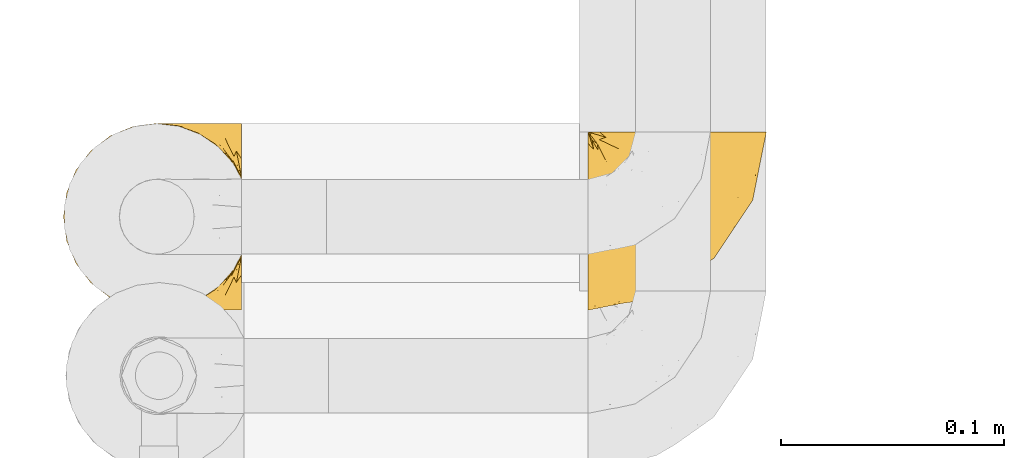
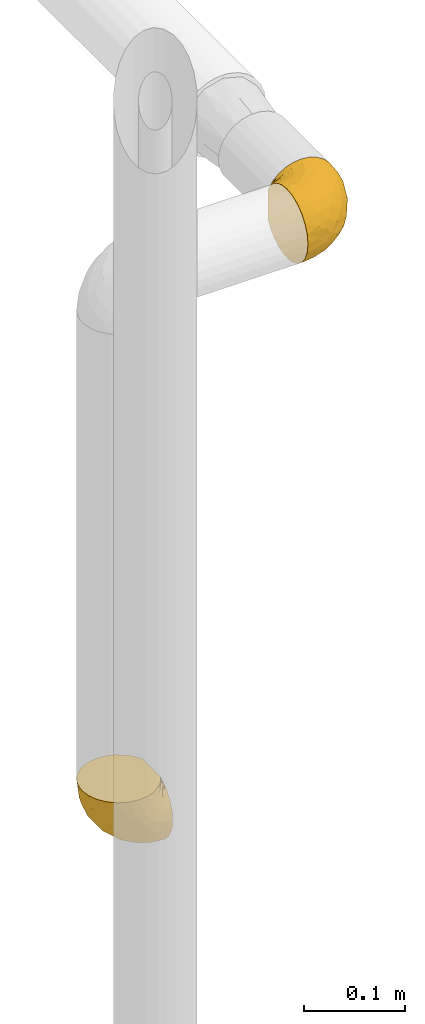
# One storey, part 125 of 827: 2 coverings.
"""IFC2X3 building model written with IfcOpenShell, lengths in millimetres."""

from ifc_helpers import new_model, entity, si_unit, converted_unit, derived_unit, direction, frame, origin, place, context, subcontext, project, spatial, faceted_brep, element, save


model = new_model("IFC2X3")

# Units and contexts
model_context = context("Model", 3, precision=0.01, world=origin(), true_north=direction((6.12303176911189e-17, 1.0)))
body_context = subcontext(model_context, "Body", "Model", "MODEL_VIEW")
ifc_project = project(units=[si_unit("LENGTHUNIT", "METRE", prefix="MILLI"), si_unit("AREAUNIT", "SQUARE_METRE"), si_unit("VOLUMEUNIT", "CUBIC_METRE"), converted_unit("PLANEANGLEUNIT", "DEGREE", entity("IfcRatioMeasure", 0.0174532925199433), si_unit("PLANEANGLEUNIT", "RADIAN"), dimensions=[0, 0, 0, 0, 0, 0, 0]), si_unit("MASSUNIT", "GRAM", prefix="KILO"), derived_unit("MASSDENSITYUNIT", [(si_unit("MASSUNIT", "GRAM", prefix="KILO"), 1), (si_unit("LENGTHUNIT", "METRE"), -3)]), derived_unit("MOMENTOFINERTIAUNIT", [(si_unit("LENGTHUNIT", "METRE"), 4)]), si_unit("TIMEUNIT", "SECOND"), si_unit("FREQUENCYUNIT", "HERTZ"), si_unit("THERMODYNAMICTEMPERATUREUNIT", "DEGREE_CELSIUS"), derived_unit("THERMALTRANSMITTANCEUNIT", [(si_unit("MASSUNIT", "GRAM", prefix="KILO"), 1), (si_unit("THERMODYNAMICTEMPERATUREUNIT", "KELVIN"), -1), (si_unit("TIMEUNIT", "SECOND"), -3)]), derived_unit("VOLUMETRICFLOWRATEUNIT", [(si_unit("LENGTHUNIT", "METRE"), 3), (si_unit("TIMEUNIT", "SECOND"), -1)]), derived_unit("MASSFLOWRATEUNIT", [(si_unit("MASSUNIT", "GRAM", prefix="KILO"), 1), (si_unit("TIMEUNIT", "SECOND"), -1)]), derived_unit("ROTATIONALFREQUENCYUNIT", [(si_unit("TIMEUNIT", "SECOND"), -1)]), si_unit("ELECTRICCURRENTUNIT", "AMPERE"), si_unit("ELECTRICVOLTAGEUNIT", "VOLT"), si_unit("POWERUNIT", "WATT"), si_unit("FORCEUNIT", "NEWTON", prefix="KILO"), si_unit("ILLUMINANCEUNIT", "LUX"), si_unit("LUMINOUSFLUXUNIT", "LUMEN"), si_unit("LUMINOUSINTENSITYUNIT", "CANDELA"), derived_unit("USERDEFINED", [(si_unit("MASSUNIT", "GRAM", prefix="KILO"), -1), (si_unit("LENGTHUNIT", "METRE"), -2), (si_unit("TIMEUNIT", "SECOND"), 3), (si_unit("LUMINOUSFLUXUNIT", "LUMEN"), 1)]), derived_unit("LINEARVELOCITYUNIT", [(si_unit("LENGTHUNIT", "METRE"), 1), (si_unit("TIMEUNIT", "SECOND"), -1)]), si_unit("PRESSUREUNIT", "PASCAL"), derived_unit("USERDEFINED", [(si_unit("LENGTHUNIT", "METRE"), -2), (si_unit("MASSUNIT", "GRAM", prefix="KILO"), 1), (si_unit("TIMEUNIT", "SECOND"), -2)]), derived_unit("LINEARFORCEUNIT", [(si_unit("MASSUNIT", "GRAM", prefix="KILO"), 1), (si_unit("LENGTHUNIT", "METRE"), 1), (si_unit("TIMEUNIT", "SECOND"), -2), (si_unit("LENGTHUNIT", "METRE"), -1)]), derived_unit("PLANARFORCEUNIT", [(si_unit("MASSUNIT", "GRAM", prefix="KILO"), 1), (si_unit("LENGTHUNIT", "METRE"), 1), (si_unit("TIMEUNIT", "SECOND"), -2), (si_unit("LENGTHUNIT", "METRE"), -2)])], contexts=[model_context])

# Site, building, storey
site_placement = place(None, origin())
site = spatial("IfcSite", under=ifc_project, at=site_placement, CompositionType="ELEMENT")
building_placement = place(site_placement, origin())
building = spatial("IfcBuilding", under=site, at=building_placement, CompositionType="ELEMENT")
storey_placement = place(building_placement, frame((0.0, 0.0, 28200.0)))
storey = spatial("IfcBuildingStorey", under=building, at=storey_placement, Name="08", CompositionType="ELEMENT", Elevation=28200.0)

# Coverings
covering_1_placement = place(storey_placement, frame((11965.87, 16522.41, 1650.82)))
element("IfcCovering", 1, at=covering_1_placement, inside=storey, Name=":ADSK_", ObjectType=":ADSK_", PredefinedType="INSULATION", context=body_context, shape_type="Brep", body=[
    faceted_brep([(57.76, 81.45, 81.15), (65.69, 81.45, 76.16), (72.32, 81.45, 69.53), (77.3, 81.45, 61.6), (80.4, 81.45, 52.75), (81.45, 81.45, 43.45), (80.39, 81.45, 34.13), (77.3, 81.45, 25.28), (72.31, 81.45, 17.35), (65.68, 81.45, 10.72), (57.75, 81.45, 5.74), (48.9, 81.45, 2.64), (39.6, 81.45, 1.6), (30.22, 81.45, 2.66), (21.33, 81.45, 5.79), (13.37, 81.45, 10.83), (6.73, 81.45, 17.53), (1.77, 81.45, 25.53), (1.77, 81.45, 26.45), (1.77, 81.45, 27.37), (1.77, 81.45, 28.17), (1.77, 81.45, 29.49), (1.77, 81.45, 30.81), (1.77, 81.45, 32.13), (1.77, 81.45, 33.45), (1.77, 81.45, 34.78), (1.77, 81.45, 36.1), (1.77, 81.45, 37.42), (1.77, 81.45, 38.74), (1.77, 81.45, 40.06), (1.77, 81.45, 41.38), (1.77, 81.45, 42.7), (1.77, 81.45, 44.02), (1.77, 81.45, 45.34), (1.77, 81.45, 46.66), (1.77, 81.45, 47.58), (1.77, 81.45, 48.5), (1.77, 81.45, 49.41), (1.77, 81.45, 50.33), (1.77, 81.45, 51.25), (1.77, 81.45, 52.17), (1.77, 81.45, 53.09), (1.77, 81.45, 54.01), (1.77, 81.45, 54.93), (1.77, 81.45, 55.85), (1.77, 81.45, 56.76), (1.77, 81.45, 57.68), (1.77, 81.45, 58.6), (1.77, 81.45, 59.52), (1.77, 81.45, 60.44), (1.77, 81.45, 61.36), (6.74, 81.45, 69.37), (13.38, 81.45, 76.07), (21.35, 81.45, 81.11), (30.24, 81.45, 84.24), (39.6, 81.45, 85.3), (48.91, 81.45, 84.24), (1.6, 76.3, 17.52), (1.6, 69.67, 10.83), (1.6, 61.7, 5.79), (1.6, 52.81, 2.66), (1.6, 43.45, 1.6), (1.6, 32.61, 3.02), (1.6, 22.52, 7.2), (1.6, 13.85, 13.85), (1.6, 7.2, 22.52), (1.6, 3.02, 32.61), (1.6, 1.6, 43.45), (1.6, 3.02, 54.28), (1.6, 7.2, 64.37), (1.6, 13.85, 73.04), (1.6, 22.52, 79.69), (1.6, 32.61, 83.87), (1.6, 43.45, 85.3), (1.6, 52.81, 84.23), (1.6, 61.7, 81.1), (1.6, 69.67, 76.06), (1.6, 76.3, 69.37), (1.6, 81.27, 61.36), (1.6, 81.27, 60.44), (1.6, 81.27, 59.12), (1.6, 81.27, 58.0), (1.6, 81.27, 56.88), (1.6, 81.27, 55.76), (1.6, 81.27, 54.64), (1.6, 81.27, 53.52), (1.6, 81.27, 52.4), (1.6, 81.27, 51.28), (1.6, 81.27, 50.16), (1.6, 81.27, 49.04), (1.6, 81.27, 47.92), (1.6, 81.27, 46.8), (1.6, 81.27, 45.68), (1.6, 81.27, 44.56), (1.6, 81.27, 43.45), (1.6, 81.27, 42.12), (1.6, 81.27, 40.8), (1.6, 81.27, 39.48), (1.6, 81.27, 38.16), (1.6, 81.27, 36.84), (1.6, 81.27, 35.52), (1.6, 81.27, 34.2), (1.6, 81.27, 32.88), (1.6, 81.27, 31.96), (1.6, 81.27, 31.05), (1.6, 81.27, 30.13), (1.6, 81.27, 29.21), (1.6, 81.27, 28.29), (1.6, 81.27, 27.37), (1.6, 81.27, 26.45), (1.6, 81.27, 25.53), (1.71, 81.31, 54.08), (1.73, 81.33, 55.16), (1.71, 81.31, 36.18), (1.72, 81.32, 35.13), (1.71, 81.31, 44.01), (1.72, 81.32, 45.08), (1.72, 81.32, 61.36), (1.72, 81.32, 59.98), (1.72, 81.32, 46.18), (1.72, 81.32, 26.74), (1.72, 81.32, 47.36), (1.72, 81.32, 29.67), (1.7, 81.3, 28.72), (1.72, 81.32, 39.77), (1.73, 81.33, 52.96), (1.72, 81.31, 51.84), (1.73, 81.33, 40.8), (1.73, 81.32, 41.87), (1.72, 81.32, 42.94), (1.72, 81.32, 27.77), (1.71, 81.31, 48.4), (1.72, 81.32, 37.21), (1.71, 81.31, 33.54), (1.72, 81.32, 32.49), (1.72, 81.32, 30.69), (1.72, 81.32, 50.69), (1.73, 81.33, 49.6), (1.72, 81.32, 56.32), (1.71, 81.31, 57.44), (1.73, 81.33, 58.88), (1.72, 81.32, 25.53), (1.74, 81.36, 61.36), (1.75, 81.4, 61.36), (1.75, 81.4, 25.53), (1.74, 81.36, 25.53), (1.64, 81.29, 61.36), (1.68, 81.3, 61.36), (1.68, 81.3, 25.53), (1.64, 81.29, 25.53), (1.74, 81.35, 31.59), (1.71, 81.31, 38.71), (8.98, 58.5, 3.97), (37.05, 71.95, 1.6), (24.69, 74.57, 3.97), (15.28, 73.93, 8.09), (16.86, 78.18, 8.09), (6.58, 78.04, 16.43), (5.71, 76.23, 15.73), (11.1, 45.99, 1.6), (10.79, 74.01, 10.79), (4.13, 73.57, 13.99), (6.62, 66.66, 8.08), (9.52, 79.09, 14.0), (6.14, 73.14, 12.83), (17.79, 60.34, 3.18), (20.6, 48.54, 1.6), (8.73, 45.36, 1.6), (23.66, 67.22, 3.28), (34.5, 62.45, 1.6), (15.32, 68.67, 6.28), (27.55, 55.49, 1.6), (3.31, 77.84, 19.06), (9.81, 68.16, 8.08), (37.68, 74.31, 1.6), (67.23, 38.78, 32.11), (76.64, 62.1, 29.62), (75.37, 50.89, 43.45), (14.58, 36.91, 2.45), (23.71, 40.37, 2.5), (34.34, 27.86, 9.73), (29.1, 15.77, 17.97), (18.02, 20.13, 10.24), (22.27, 31.54, 4.78), (10.97, 28.25, 4.78), (56.79, 57.26, 8.01), (60.76, 69.99, 8.01), (67.04, 64.58, 13.85), (36.11, 50.64, 2.42), (68.85, 51.97, 21.17), (24.58, 5.72, 35.73), (21.54, 7.42, 27.43), (78.4, 66.14, 43.45), (14.11, 11.35, 17.97), (53.42, 21.64, 35.71), (58.19, 28.57, 29.47), (44.49, 55.38, 3.41), (51.77, 68.51, 3.94), (73.69, 67.48, 21.17), (45.89, 40.78, 7.92), (35.97, 41.53, 4.25), (56.55, 46.11, 11.75), (60.03, 40.32, 18.31), (63.64, 38.36, 24.94), (34.98, 11.84, 28.78), (40.58, 12.56, 35.82), (32.15, 7.67, 43.45), (47.26, 19.39, 28.38), (58.06, 24.98, 43.45), (66.71, 37.94, 43.45), (16.9, 4.64, 43.45), (52.08, 28.09, 21.21), (41.21, 23.73, 16.48), (49.76, 34.03, 13.85), (45.11, 16.33, 43.45), (15.65, 29.29, 82.11), (24.57, 5.77, 51.41), (50.54, 21.44, 57.45), (67.25, 38.8, 54.78), (67.06, 64.58, 73.03), (73.7, 67.49, 65.7), (26.13, 22.9, 76.65), (19.54, 12.54, 68.92), (38.96, 20.04, 68.01), (56.8, 57.26, 78.88), (60.77, 69.99, 78.88), (51.78, 68.51, 82.94), (59.09, 34.54, 64.44), (19.25, 38.81, 84.49), (20.6, 48.54, 85.3), (11.1, 45.99, 85.3), (37.68, 74.31, 85.3), (15.21, 5.36, 57.84), (12.76, 18.96, 76.65), (40.93, 12.79, 51.19), (76.65, 62.11, 57.26), (39.5, 33.14, 78.14), (25.01, 33.44, 82.35), (68.86, 51.98, 65.7), (26.7, 43.42, 84.61), (34.95, 48.62, 84.36), (34.5, 62.45, 85.3), (27.55, 55.49, 85.3), (61.27, 49.68, 73.03), (44.5, 55.37, 83.48), (37.05, 71.95, 85.3), (10.25, 36.37, 84.54), (49.78, 34.04, 73.03), (47.51, 44.1, 79.54), (29.38, 9.99, 59.46), (40.01, 26.41, 73.5), (33.36, 39.19, 82.57), (8.98, 58.5, 82.92), (23.67, 67.22, 83.62), (24.71, 74.57, 82.92), (15.29, 73.92, 78.81), (4.13, 73.57, 72.9), (6.14, 73.14, 74.06), (4.96, 66.19, 78.81), (9.81, 68.16, 78.81), (3.31, 77.84, 67.83), (5.7, 76.23, 71.15), (9.53, 79.08, 72.91), (6.59, 78.04, 70.47), (16.63, 77.18, 78.81), (15.34, 68.66, 80.62), (10.8, 74.0, 76.11), (17.79, 60.34, 83.71)], [[[0, 1, 2, 3, 4, 5, 6, 7, 8, 9, 10, 11, 12, 13, 14, 15, 16, 17, 18, 19, 20, 21, 22, 23, 24, 25, 26, 27, 28, 29, 30, 31, 32, 33, 34, 35, 36, 37, 38, 39, 40, 41, 42, 43, 44, 45, 46, 47, 48, 49, 50, 51, 52, 53, 54, 55, 56]], [[57, 58, 59, 60, 61, 62, 63, 64, 65, 66, 67, 68, 69, 70, 71, 72, 73, 74, 75, 76, 77, 78, 79, 80, 81, 82, 83, 84, 85, 86, 87, 88, 89, 90, 91, 92, 93, 94, 95, 96, 97, 98, 99, 100, 101, 102, 103, 104, 105, 106, 107, 108, 109, 110]], [[111, 84, 112]], [[113, 26, 114]], [[114, 101, 100]], [[115, 93, 116]], [[79, 117, 118]], [[33, 116, 119]], [[117, 49, 118]], [[19, 18, 120]], [[119, 121, 34]], [[122, 21, 123]], [[97, 96, 124]], [[86, 125, 126]], [[116, 92, 119]], [[127, 96, 128]], [[32, 129, 115]], [[19, 120, 130]], [[121, 90, 131]], [[94, 115, 129]], [[115, 116, 32]], [[118, 49, 48]], [[113, 99, 132]], [[133, 114, 25]], [[24, 134, 133]], [[135, 22, 122]], [[136, 137, 88]], [[84, 83, 112]], [[138, 82, 139]], [[130, 20, 19]], [[118, 48, 140]], [[81, 140, 139]], [[123, 21, 20]], [[141, 120, 18]], [[139, 82, 81]], [[130, 107, 123]], [[49, 117, 142, 143, 50]], [[18, 17, 144, 145, 141]], [[79, 78, 146, 147, 117]], [[109, 141, 148, 149, 110]], [[102, 133, 134]], [[105, 135, 122]], [[118, 80, 79]], [[80, 118, 140]], [[120, 109, 108]], [[47, 46, 140, 48]], [[81, 80, 140]], [[44, 112, 138]], [[93, 115, 94]], [[46, 139, 140]], [[46, 45, 139]], [[139, 45, 138]], [[138, 112, 83]], [[85, 84, 111]], [[112, 43, 111]], [[83, 82, 138]], [[106, 122, 123]], [[105, 122, 106]], [[21, 122, 22]], [[124, 29, 28]], [[33, 32, 116]], [[128, 129, 31]], [[32, 31, 129]], [[34, 33, 119]], [[116, 93, 92]], [[129, 95, 94]], [[95, 129, 128]], [[41, 40, 125, 42]], [[119, 91, 121]], [[36, 35, 131, 37]], [[137, 131, 89]], [[121, 131, 35]], [[90, 121, 91]], [[119, 92, 91]], [[136, 126, 39]], [[125, 86, 85]], [[42, 125, 111]], [[85, 111, 125]], [[150, 23, 22]], [[130, 108, 107]], [[130, 123, 20]], [[107, 106, 123]], [[137, 37, 131]], [[136, 38, 137]], [[89, 88, 137]], [[131, 90, 89]], [[124, 151, 97]], [[40, 39, 126]], [[87, 126, 136]], [[86, 126, 87]], [[136, 88, 87]], [[40, 126, 125]], [[39, 38, 136]], [[95, 128, 96]], [[30, 128, 31]], [[29, 124, 127]], [[127, 128, 30]], [[151, 124, 28]], [[127, 30, 29]], [[127, 124, 96]], [[151, 98, 97]], [[45, 44, 138]], [[26, 113, 132]], [[113, 100, 99]], [[132, 151, 27]], [[27, 26, 132]], [[26, 25, 114]], [[100, 113, 114]], [[101, 133, 102]], [[133, 101, 114]], [[28, 27, 151]], [[132, 99, 98]], [[23, 134, 24]], [[25, 24, 133]], [[134, 23, 150]], [[135, 104, 150]], [[150, 104, 103]], [[103, 102, 134]], [[130, 120, 108]], [[109, 120, 141]], [[42, 111, 43]], [[112, 44, 43]], [[104, 135, 105]], [[134, 150, 103]], [[135, 150, 22]], [[35, 34, 121]], [[137, 38, 37]], [[98, 151, 132]], [[59, 152, 60]], [[13, 153, 154]], [[155, 156, 154]], [[157, 158, 141]], [[159, 60, 152]], [[160, 157, 155]], [[161, 162, 58]], [[58, 162, 59]], [[144, 16, 163]], [[58, 57, 161]], [[162, 161, 164]], [[157, 163, 155]], [[163, 16, 15]], [[57, 149, 161]], [[152, 165, 166]], [[157, 144, 163]], [[60, 159, 167, 61]], [[156, 14, 154]], [[163, 156, 155]], [[155, 154, 168]], [[168, 154, 169]], [[155, 170, 160]], [[57, 110, 149]], [[144, 17, 16]], [[156, 15, 14]], [[171, 165, 168]], [[158, 164, 172]], [[14, 13, 154]], [[157, 141, 145, 144]], [[173, 164, 158]], [[173, 160, 170]], [[171, 166, 165]], [[168, 165, 170]], [[168, 169, 171]], [[152, 173, 165]], [[170, 155, 168]], [[165, 173, 170]], [[160, 173, 158]], [[172, 149, 148]], [[148, 141, 158]], [[158, 157, 160]], [[152, 166, 159]], [[173, 152, 162]], [[59, 162, 152]], [[13, 12, 174, 153]], [[153, 169, 154]], [[15, 156, 163]], [[162, 164, 173]], [[172, 164, 161]], [[149, 172, 161]], [[158, 172, 148]], [[175, 176, 177]], [[178, 166, 179]], [[180, 181, 182]], [[183, 184, 178]], [[185, 186, 187]], [[171, 188, 179]], [[174, 12, 11]], [[189, 176, 175]], [[190, 66, 191]], [[176, 6, 192]], [[193, 65, 64]], [[63, 184, 182]], [[63, 182, 64]], [[65, 193, 191]], [[184, 63, 62]], [[175, 194, 195]], [[196, 169, 197]], [[174, 11, 197]], [[8, 7, 198]], [[187, 9, 8]], [[197, 169, 153, 174]], [[197, 11, 10]], [[186, 197, 10]], [[199, 180, 200]], [[197, 185, 196]], [[201, 189, 202]], [[201, 187, 189]], [[195, 203, 175]], [[191, 204, 190]], [[176, 7, 6]], [[177, 176, 192]], [[189, 198, 176]], [[65, 191, 66]], [[198, 187, 8]], [[205, 206, 190]], [[9, 186, 10]], [[181, 207, 204]], [[208, 175, 177, 209]], [[66, 190, 210]], [[211, 212, 213]], [[190, 204, 205]], [[180, 182, 183]], [[193, 182, 181]], [[62, 61, 167]], [[196, 185, 199]], [[196, 200, 188]], [[6, 5, 192]], [[176, 198, 7]], [[187, 198, 189]], [[187, 186, 9]], [[197, 186, 185]], [[200, 180, 183]], [[180, 213, 212]], [[179, 183, 178]], [[185, 201, 199]], [[210, 190, 206]], [[210, 67, 66]], [[205, 204, 207]], [[194, 205, 207]], [[194, 214, 205]], [[195, 194, 207]], [[208, 194, 175]], [[207, 211, 195]], [[202, 203, 211]], [[212, 207, 181]], [[202, 211, 213]], [[201, 202, 213]], [[189, 175, 203]], [[199, 201, 213]], [[187, 201, 185]], [[180, 199, 213]], [[196, 199, 200]], [[211, 203, 195]], [[189, 203, 202]], [[207, 212, 211]], [[180, 212, 181]], [[214, 194, 208]], [[214, 206, 205]], [[196, 188, 169]], [[181, 204, 191]], [[182, 193, 64]], [[191, 193, 181]], [[178, 62, 167]], [[182, 184, 183]], [[62, 178, 184]], [[178, 167, 159, 166]], [[171, 179, 166]], [[200, 183, 179]], [[179, 188, 200]], [[169, 188, 171]], [[71, 215, 72]], [[206, 216, 210]], [[217, 208, 218]], [[216, 68, 210]], [[219, 220, 2]], [[221, 222, 223]], [[224, 225, 226]], [[227, 223, 217]], [[228, 229, 230]], [[56, 231, 226]], [[232, 222, 69]], [[56, 55, 231]], [[70, 233, 71]], [[71, 233, 215]], [[0, 56, 226]], [[208, 217, 234]], [[218, 177, 235]], [[221, 236, 237]], [[238, 220, 219]], [[1, 219, 2]], [[68, 216, 232]], [[235, 3, 220]], [[235, 192, 4]], [[1, 0, 225]], [[228, 239, 229]], [[240, 241, 242]], [[243, 238, 219]], [[224, 226, 244]], [[226, 241, 244]], [[3, 235, 4]], [[69, 222, 70]], [[225, 219, 1]], [[218, 235, 238]], [[243, 219, 224]], [[218, 227, 217]], [[3, 2, 220]], [[218, 208, 209, 177]], [[226, 231, 245, 241]], [[215, 228, 246]], [[247, 248, 236]], [[248, 224, 244]], [[223, 222, 249]], [[233, 222, 221]], [[242, 239, 240]], [[248, 247, 243]], [[217, 223, 249]], [[250, 247, 236]], [[216, 234, 249]], [[218, 238, 227]], [[192, 235, 177]], [[192, 5, 4]], [[72, 246, 73]], [[235, 220, 238]], [[226, 225, 0]], [[219, 225, 224]], [[240, 248, 244]], [[239, 242, 229]], [[236, 248, 251]], [[68, 67, 210]], [[234, 216, 206]], [[216, 249, 232]], [[234, 206, 214, 208]], [[249, 234, 217]], [[222, 232, 249]], [[69, 68, 232]], [[246, 228, 230]], [[237, 228, 215]], [[243, 227, 238]], [[223, 227, 247]], [[73, 246, 230]], [[215, 246, 72]], [[248, 243, 224]], [[227, 243, 247]], [[237, 236, 251]], [[250, 221, 223]], [[222, 233, 70]], [[215, 233, 221]], [[221, 237, 215]], [[239, 237, 251]], [[237, 239, 228]], [[239, 251, 240]], [[248, 240, 251]], [[241, 240, 244]], [[221, 250, 236]], [[223, 247, 250]], [[74, 230, 252]], [[253, 254, 255]], [[146, 77, 256]], [[257, 258, 259]], [[260, 256, 257]], [[260, 261, 147]], [[75, 74, 252]], [[51, 143, 262]], [[263, 143, 142, 117]], [[256, 77, 76]], [[252, 258, 75]], [[253, 241, 254]], [[254, 245, 54]], [[258, 256, 76]], [[53, 52, 264]], [[255, 265, 253]], [[254, 264, 255]], [[255, 264, 262]], [[75, 258, 76]], [[265, 255, 266]], [[255, 262, 263]], [[51, 50, 143]], [[54, 245, 231, 55]], [[51, 262, 52]], [[253, 267, 242]], [[254, 54, 53]], [[266, 259, 265]], [[146, 78, 77]], [[263, 117, 261]], [[146, 256, 260]], [[257, 259, 261]], [[267, 253, 265]], [[229, 267, 252]], [[242, 267, 229]], [[242, 241, 253]], [[252, 267, 259]], [[255, 263, 266]], [[259, 267, 265]], [[261, 117, 147]], [[263, 261, 266]], [[259, 266, 261]], [[230, 74, 73]], [[230, 229, 252]], [[259, 258, 252]], [[254, 241, 245]], [[53, 264, 254]], [[52, 262, 264]], [[143, 263, 262]], [[258, 257, 256]], [[261, 260, 257]], [[146, 260, 147]]]),
])
covering_2_placement = place(storey_placement, frame((11730.77, 16522.41, 1006.55)))
element("IfcCovering", 2, at=covering_2_placement, inside=storey, Name=":ADSK_", ObjectType=":ADSK_", PredefinedType="INSULATION", context=body_context, shape_type="Brep", body=[
    faceted_brep([(81.45, 5.74, 25.28), (81.45, 10.73, 17.35), (81.45, 17.36, 10.72), (81.45, 25.29, 5.74), (81.45, 34.14, 2.64), (81.45, 43.45, 1.6), (81.45, 52.76, 2.65), (81.45, 61.61, 5.74), (81.45, 69.54, 10.73), (81.45, 76.17, 17.36), (81.45, 81.15, 25.29), (81.45, 84.25, 34.14), (81.45, 85.3, 43.45), (81.45, 84.23, 52.82), (81.45, 81.1, 61.71), (81.45, 76.06, 69.67), (81.45, 69.36, 76.31), (81.45, 61.36, 81.27), (81.45, 60.44, 81.27), (81.45, 59.52, 81.27), (81.45, 58.72, 81.27), (81.45, 57.4, 81.27), (81.45, 56.08, 81.27), (81.45, 54.76, 81.27), (81.45, 53.44, 81.27), (81.45, 52.12, 81.27), (81.45, 50.8, 81.27), (81.45, 49.47, 81.27), (81.45, 48.15, 81.27), (81.45, 46.83, 81.27), (81.45, 45.51, 81.27), (81.45, 44.19, 81.27), (81.45, 42.87, 81.27), (81.45, 41.55, 81.27), (81.45, 40.23, 81.27), (81.45, 39.31, 81.27), (81.45, 38.39, 81.27), (81.45, 37.48, 81.27), (81.45, 36.56, 81.27), (81.45, 35.64, 81.27), (81.45, 34.72, 81.27), (81.45, 33.8, 81.27), (81.45, 32.88, 81.27), (81.45, 31.96, 81.27), (81.45, 31.05, 81.27), (81.45, 30.13, 81.27), (81.45, 29.21, 81.27), (81.45, 28.29, 81.27), (81.45, 27.37, 81.27), (81.45, 26.45, 81.27), (81.45, 25.53, 81.27), (81.45, 17.52, 76.3), (81.45, 10.82, 69.66), (81.45, 5.78, 61.69), (81.45, 2.65, 52.8), (81.45, 1.6, 43.45), (81.45, 2.65, 34.13), (76.3, 69.37, 81.45), (69.67, 76.06, 81.45), (61.7, 81.1, 81.45), (52.81, 84.23, 81.45), (43.45, 85.3, 81.45), (32.61, 83.87, 81.45), (22.52, 79.69, 81.45), (13.85, 73.04, 81.45), (7.2, 64.37, 81.45), (3.02, 54.28, 81.45), (1.6, 43.45, 81.45), (3.02, 32.61, 81.45), (7.2, 22.52, 81.45), (13.85, 13.85, 81.45), (22.52, 7.2, 81.45), (32.61, 3.02, 81.45), (43.45, 1.6, 81.45), (52.81, 2.66, 81.45), (61.7, 5.79, 81.45), (69.67, 10.83, 81.45), (76.3, 17.52, 81.45), (81.27, 25.53, 81.45), (81.27, 26.45, 81.45), (81.27, 27.77, 81.45), (81.27, 28.89, 81.45), (81.27, 30.01, 81.45), (81.27, 31.13, 81.45), (81.27, 32.25, 81.45), (81.27, 33.37, 81.45), (81.27, 34.49, 81.45), (81.27, 35.61, 81.45), (81.27, 36.73, 81.45), (81.27, 37.85, 81.45), (81.27, 38.97, 81.45), (81.27, 40.09, 81.45), (81.27, 41.21, 81.45), (81.27, 42.33, 81.45), (81.27, 43.45, 81.45), (81.27, 44.77, 81.45), (81.27, 46.09, 81.45), (81.27, 47.41, 81.45), (81.27, 48.73, 81.45), (81.27, 50.05, 81.45), (81.27, 51.37, 81.45), (81.27, 52.69, 81.45), (81.27, 54.01, 81.45), (81.27, 54.93, 81.45), (81.27, 55.85, 81.45), (81.27, 56.76, 81.45), (81.27, 57.68, 81.45), (81.27, 58.6, 81.45), (81.27, 59.52, 81.45), (81.27, 60.44, 81.45), (81.27, 61.36, 81.45), (81.31, 32.81, 81.33), (81.33, 31.73, 81.32), (81.31, 50.71, 81.33), (81.32, 51.76, 81.32), (81.31, 42.89, 81.33), (81.32, 41.81, 81.32), (81.32, 25.53, 81.32), (81.32, 26.91, 81.32), (81.32, 40.71, 81.32), (81.32, 60.15, 81.32), (81.32, 39.53, 81.32), (81.32, 57.22, 81.32), (81.3, 58.17, 81.34), (81.32, 47.12, 81.32), (81.33, 33.93, 81.31), (81.31, 35.05, 81.33), (81.33, 46.09, 81.31), (81.32, 45.02, 81.32), (81.32, 43.95, 81.33), (81.32, 59.12, 81.32), (81.31, 38.49, 81.33), (81.32, 49.68, 81.32), (81.31, 53.35, 81.33), (81.32, 54.4, 81.32), (81.32, 56.2, 81.32), (81.32, 36.2, 81.32), (81.33, 37.29, 81.31), (81.32, 30.57, 81.32), (81.31, 29.45, 81.33), (81.33, 28.01, 81.31), (81.32, 61.36, 81.32), (81.36, 25.53, 81.3), (81.4, 25.53, 81.29), (81.4, 61.36, 81.29), (81.36, 61.36, 81.3), (81.29, 25.53, 81.4), (81.3, 25.53, 81.36), (81.3, 61.36, 81.36), (81.29, 61.36, 81.4), (81.35, 55.3, 81.3), (81.31, 48.18, 81.33), (58.5, 82.92, 74.06), (71.95, 85.3, 45.99), (74.57, 82.92, 58.35), (73.93, 78.8, 67.76), (78.18, 78.8, 66.18), (78.04, 70.46, 76.46), (76.23, 71.16, 77.33), (45.99, 85.3, 71.95), (74.01, 76.1, 72.25), (73.57, 72.9, 78.91), (66.66, 78.81, 76.42), (79.09, 72.89, 73.52), (73.14, 74.06, 76.9), (60.34, 83.71, 65.25), (48.54, 85.3, 62.45), (45.36, 85.3, 74.31), (67.22, 83.61, 59.38), (62.45, 85.3, 48.54), (68.67, 80.61, 67.72), (55.49, 85.3, 55.49), (77.84, 67.83, 79.73), (68.16, 78.81, 73.23), (74.31, 85.3, 45.36), (38.78, 54.78, 15.81), (62.1, 57.27, 6.4), (50.89, 43.45, 7.67), (36.91, 84.45, 68.46), (40.37, 84.39, 59.33), (27.86, 77.16, 48.7), (15.77, 68.92, 53.94), (20.13, 76.65, 65.02), (31.54, 82.11, 60.77), (28.25, 82.11, 72.07), (57.26, 78.88, 26.25), (69.99, 78.88, 22.29), (64.58, 73.04, 16.0), (50.64, 84.47, 46.93), (51.97, 65.72, 14.19), (5.72, 51.16, 58.46), (7.42, 59.46, 61.51), (66.14, 43.45, 4.64), (11.35, 68.92, 68.93), (21.64, 51.18, 29.62), (28.57, 57.42, 24.85), (55.38, 83.48, 38.55), (68.51, 82.95, 31.27), (67.48, 65.72, 9.35), (40.78, 78.97, 37.15), (41.53, 82.64, 47.07), (46.11, 75.14, 26.49), (40.32, 68.58, 23.01), (38.36, 61.95, 19.4), (11.84, 58.11, 48.06), (12.56, 51.07, 42.46), (7.67, 43.45, 50.89), (19.39, 58.51, 35.78), (24.98, 43.45, 24.98), (37.94, 43.45, 16.33), (4.64, 43.45, 66.14), (28.09, 65.68, 30.96), (23.73, 70.41, 41.83), (34.03, 73.04, 33.28), (16.33, 43.45, 37.94), (29.29, 4.78, 67.39), (5.77, 35.48, 58.47), (21.44, 29.45, 32.5), (38.8, 32.11, 15.79), (64.58, 13.86, 15.99), (67.49, 21.19, 9.34), (22.9, 10.24, 56.91), (12.54, 17.97, 63.5), (20.04, 18.88, 44.08), (57.26, 8.01, 26.24), (69.99, 8.01, 22.27), (68.51, 3.95, 31.26), (34.54, 22.45, 23.95), (38.81, 2.4, 63.79), (48.54, 1.6, 62.45), (45.99, 1.6, 71.95), (74.31, 1.6, 45.36), (5.36, 29.05, 67.83), (18.96, 10.24, 70.28), (12.79, 35.7, 42.11), (62.11, 29.63, 6.39), (33.14, 8.75, 43.54), (33.44, 4.54, 58.03), (51.98, 21.19, 14.18), (43.42, 2.28, 56.34), (48.62, 2.53, 48.09), (62.45, 1.6, 48.54), (55.49, 1.6, 55.49), (49.68, 13.86, 21.78), (55.37, 3.41, 38.54), (71.95, 1.6, 45.99), (36.37, 2.35, 72.79), (34.04, 13.86, 33.26), (44.1, 7.35, 35.53), (9.99, 27.43, 53.66), (26.41, 13.39, 43.03), (39.19, 4.32, 49.68), (58.5, 3.97, 74.06), (67.22, 3.27, 59.37), (74.57, 3.97, 58.34), (73.92, 8.08, 67.75), (73.57, 13.99, 78.91), (73.14, 12.83, 76.9), (66.19, 8.08, 78.08), (68.16, 8.08, 73.23), (77.84, 19.06, 79.73), (76.23, 15.74, 77.34), (79.08, 13.98, 73.51), (78.04, 16.42, 76.45), (77.18, 8.08, 66.41), (68.66, 6.27, 67.7), (74.0, 10.78, 72.24), (60.34, 3.18, 65.25)], [[[0, 1, 2, 3, 4, 5, 6, 7, 8, 9, 10, 11, 12, 13, 14, 15, 16, 17, 18, 19, 20, 21, 22, 23, 24, 25, 26, 27, 28, 29, 30, 31, 32, 33, 34, 35, 36, 37, 38, 39, 40, 41, 42, 43, 44, 45, 46, 47, 48, 49, 50, 51, 52, 53, 54, 55, 56]], [[57, 58, 59, 60, 61, 62, 63, 64, 65, 66, 67, 68, 69, 70, 71, 72, 73, 74, 75, 76, 77, 78, 79, 80, 81, 82, 83, 84, 85, 86, 87, 88, 89, 90, 91, 92, 93, 94, 95, 96, 97, 98, 99, 100, 101, 102, 103, 104, 105, 106, 107, 108, 109, 110]], [[111, 84, 112]], [[113, 26, 114]], [[114, 101, 100]], [[115, 93, 116]], [[79, 117, 118]], [[33, 116, 119]], [[117, 49, 118]], [[19, 18, 120]], [[119, 121, 34]], [[122, 21, 123]], [[97, 96, 124]], [[86, 125, 126]], [[116, 92, 119]], [[127, 96, 128]], [[32, 129, 115]], [[19, 120, 130]], [[121, 90, 131]], [[94, 115, 129]], [[115, 116, 32]], [[118, 49, 48]], [[113, 99, 132]], [[133, 114, 25]], [[24, 134, 133]], [[135, 22, 122]], [[136, 137, 88]], [[84, 83, 112]], [[138, 82, 139]], [[130, 20, 19]], [[118, 48, 140]], [[81, 140, 139]], [[123, 21, 20]], [[141, 120, 18]], [[139, 82, 81]], [[130, 107, 123]], [[49, 117, 142, 143, 50]], [[18, 17, 144, 145, 141]], [[79, 78, 146, 147, 117]], [[109, 141, 148, 149, 110]], [[102, 133, 134]], [[105, 135, 122]], [[118, 80, 79]], [[80, 118, 140]], [[120, 109, 108]], [[47, 46, 140, 48]], [[81, 80, 140]], [[44, 112, 138]], [[93, 115, 94]], [[46, 139, 140]], [[46, 45, 139]], [[139, 45, 138]], [[138, 112, 83]], [[85, 84, 111]], [[112, 43, 111]], [[83, 82, 138]], [[106, 122, 123]], [[105, 122, 106]], [[21, 122, 22]], [[124, 29, 28]], [[33, 32, 116]], [[128, 129, 31]], [[32, 31, 129]], [[34, 33, 119]], [[116, 93, 92]], [[129, 95, 94]], [[95, 129, 128]], [[41, 40, 125, 42]], [[119, 91, 121]], [[36, 35, 131, 37]], [[137, 131, 89]], [[121, 131, 35]], [[90, 121, 91]], [[119, 92, 91]], [[136, 126, 39]], [[125, 86, 85]], [[42, 125, 111]], [[85, 111, 125]], [[150, 23, 22]], [[130, 108, 107]], [[130, 123, 20]], [[107, 106, 123]], [[137, 37, 131]], [[136, 38, 137]], [[89, 88, 137]], [[131, 90, 89]], [[124, 151, 97]], [[40, 39, 126]], [[87, 126, 136]], [[86, 126, 87]], [[136, 88, 87]], [[40, 126, 125]], [[39, 38, 136]], [[95, 128, 96]], [[30, 128, 31]], [[29, 124, 127]], [[127, 128, 30]], [[151, 124, 28]], [[127, 30, 29]], [[127, 124, 96]], [[151, 98, 97]], [[45, 44, 138]], [[26, 113, 132]], [[113, 100, 99]], [[132, 151, 27]], [[27, 26, 132]], [[26, 25, 114]], [[100, 113, 114]], [[101, 133, 102]], [[133, 101, 114]], [[28, 27, 151]], [[132, 99, 98]], [[23, 134, 24]], [[25, 24, 133]], [[134, 23, 150]], [[135, 104, 150]], [[150, 104, 103]], [[103, 102, 134]], [[130, 120, 108]], [[109, 120, 141]], [[42, 111, 43]], [[112, 44, 43]], [[104, 135, 105]], [[134, 150, 103]], [[135, 150, 22]], [[35, 34, 121]], [[137, 38, 37]], [[98, 151, 132]], [[59, 152, 60]], [[13, 153, 154]], [[155, 156, 154]], [[157, 158, 141]], [[159, 60, 152]], [[160, 157, 155]], [[161, 162, 58]], [[58, 162, 59]], [[144, 16, 163]], [[58, 57, 161]], [[162, 161, 164]], [[157, 163, 155]], [[163, 16, 15]], [[57, 149, 161]], [[152, 165, 166]], [[157, 144, 163]], [[60, 159, 167, 61]], [[156, 14, 154]], [[163, 156, 155]], [[155, 154, 168]], [[168, 154, 169]], [[155, 170, 160]], [[57, 110, 149]], [[144, 17, 16]], [[156, 15, 14]], [[171, 165, 168]], [[158, 164, 172]], [[14, 13, 154]], [[157, 141, 145, 144]], [[173, 164, 158]], [[173, 160, 170]], [[171, 166, 165]], [[168, 165, 170]], [[168, 169, 171]], [[152, 173, 165]], [[170, 155, 168]], [[165, 173, 170]], [[160, 173, 158]], [[172, 149, 148]], [[148, 141, 158]], [[158, 157, 160]], [[152, 166, 159]], [[173, 152, 162]], [[59, 162, 152]], [[13, 12, 174, 153]], [[153, 169, 154]], [[15, 156, 163]], [[162, 164, 173]], [[172, 164, 161]], [[149, 172, 161]], [[158, 172, 148]], [[175, 176, 177]], [[178, 166, 179]], [[180, 181, 182]], [[183, 184, 178]], [[185, 186, 187]], [[171, 188, 179]], [[174, 12, 11]], [[189, 176, 175]], [[190, 66, 191]], [[176, 6, 192]], [[193, 65, 64]], [[63, 184, 182]], [[63, 182, 64]], [[65, 193, 191]], [[184, 63, 62]], [[175, 194, 195]], [[196, 169, 197]], [[174, 11, 197]], [[8, 7, 198]], [[187, 9, 8]], [[197, 169, 153, 174]], [[197, 11, 10]], [[186, 197, 10]], [[199, 180, 200]], [[197, 185, 196]], [[201, 189, 202]], [[201, 187, 189]], [[195, 203, 175]], [[191, 204, 190]], [[176, 7, 6]], [[177, 176, 192]], [[189, 198, 176]], [[65, 191, 66]], [[198, 187, 8]], [[205, 206, 190]], [[9, 186, 10]], [[181, 207, 204]], [[208, 175, 177, 209]], [[66, 190, 210]], [[211, 212, 213]], [[190, 204, 205]], [[180, 182, 183]], [[193, 182, 181]], [[62, 61, 167]], [[196, 185, 199]], [[196, 200, 188]], [[6, 5, 192]], [[176, 198, 7]], [[187, 198, 189]], [[187, 186, 9]], [[197, 186, 185]], [[200, 180, 183]], [[180, 213, 212]], [[179, 183, 178]], [[185, 201, 199]], [[210, 190, 206]], [[210, 67, 66]], [[205, 204, 207]], [[194, 205, 207]], [[194, 214, 205]], [[195, 194, 207]], [[208, 194, 175]], [[207, 211, 195]], [[202, 203, 211]], [[212, 207, 181]], [[202, 211, 213]], [[201, 202, 213]], [[189, 175, 203]], [[199, 201, 213]], [[187, 201, 185]], [[180, 199, 213]], [[196, 199, 200]], [[211, 203, 195]], [[189, 203, 202]], [[207, 212, 211]], [[180, 212, 181]], [[214, 194, 208]], [[214, 206, 205]], [[196, 188, 169]], [[181, 204, 191]], [[182, 193, 64]], [[191, 193, 181]], [[178, 62, 167]], [[182, 184, 183]], [[62, 178, 184]], [[178, 167, 159, 166]], [[171, 179, 166]], [[200, 183, 179]], [[179, 188, 200]], [[169, 188, 171]], [[71, 215, 72]], [[206, 216, 210]], [[217, 208, 218]], [[216, 68, 210]], [[219, 220, 2]], [[221, 222, 223]], [[224, 225, 226]], [[227, 223, 217]], [[228, 229, 230]], [[56, 231, 226]], [[232, 222, 69]], [[56, 55, 231]], [[70, 233, 71]], [[71, 233, 215]], [[0, 56, 226]], [[208, 217, 234]], [[218, 177, 235]], [[221, 236, 237]], [[238, 220, 219]], [[1, 219, 2]], [[68, 216, 232]], [[235, 3, 220]], [[235, 192, 4]], [[1, 0, 225]], [[228, 239, 229]], [[240, 241, 242]], [[243, 238, 219]], [[224, 226, 244]], [[226, 241, 244]], [[3, 235, 4]], [[69, 222, 70]], [[225, 219, 1]], [[218, 235, 238]], [[243, 219, 224]], [[218, 227, 217]], [[3, 2, 220]], [[218, 208, 209, 177]], [[226, 231, 245, 241]], [[215, 228, 246]], [[247, 248, 236]], [[248, 224, 244]], [[223, 222, 249]], [[233, 222, 221]], [[242, 239, 240]], [[248, 247, 243]], [[217, 223, 249]], [[250, 247, 236]], [[216, 234, 249]], [[218, 238, 227]], [[192, 235, 177]], [[192, 5, 4]], [[72, 246, 73]], [[235, 220, 238]], [[226, 225, 0]], [[219, 225, 224]], [[240, 248, 244]], [[239, 242, 229]], [[236, 248, 251]], [[68, 67, 210]], [[234, 216, 206]], [[216, 249, 232]], [[234, 206, 214, 208]], [[249, 234, 217]], [[222, 232, 249]], [[69, 68, 232]], [[246, 228, 230]], [[237, 228, 215]], [[243, 227, 238]], [[223, 227, 247]], [[73, 246, 230]], [[215, 246, 72]], [[248, 243, 224]], [[227, 243, 247]], [[237, 236, 251]], [[250, 221, 223]], [[222, 233, 70]], [[215, 233, 221]], [[221, 237, 215]], [[239, 237, 251]], [[237, 239, 228]], [[239, 251, 240]], [[248, 240, 251]], [[241, 240, 244]], [[221, 250, 236]], [[223, 247, 250]], [[74, 230, 252]], [[253, 254, 255]], [[146, 77, 256]], [[257, 258, 259]], [[260, 256, 257]], [[260, 261, 147]], [[75, 74, 252]], [[51, 143, 262]], [[263, 143, 142, 117]], [[256, 77, 76]], [[252, 258, 75]], [[253, 241, 254]], [[254, 245, 54]], [[258, 256, 76]], [[53, 52, 264]], [[255, 265, 253]], [[254, 264, 255]], [[255, 264, 262]], [[75, 258, 76]], [[265, 255, 266]], [[255, 262, 263]], [[51, 50, 143]], [[54, 245, 231, 55]], [[51, 262, 52]], [[253, 267, 242]], [[254, 54, 53]], [[266, 259, 265]], [[146, 78, 77]], [[263, 117, 261]], [[146, 256, 260]], [[257, 259, 261]], [[267, 253, 265]], [[229, 267, 252]], [[242, 267, 229]], [[242, 241, 253]], [[252, 267, 259]], [[255, 263, 266]], [[259, 267, 265]], [[261, 117, 147]], [[263, 261, 266]], [[259, 266, 261]], [[230, 74, 73]], [[230, 229, 252]], [[259, 258, 252]], [[254, 241, 245]], [[53, 264, 254]], [[52, 262, 264]], [[143, 263, 262]], [[258, 257, 256]], [[261, 260, 257]], [[146, 260, 147]]]),
])

save(model, "model.ifc")
